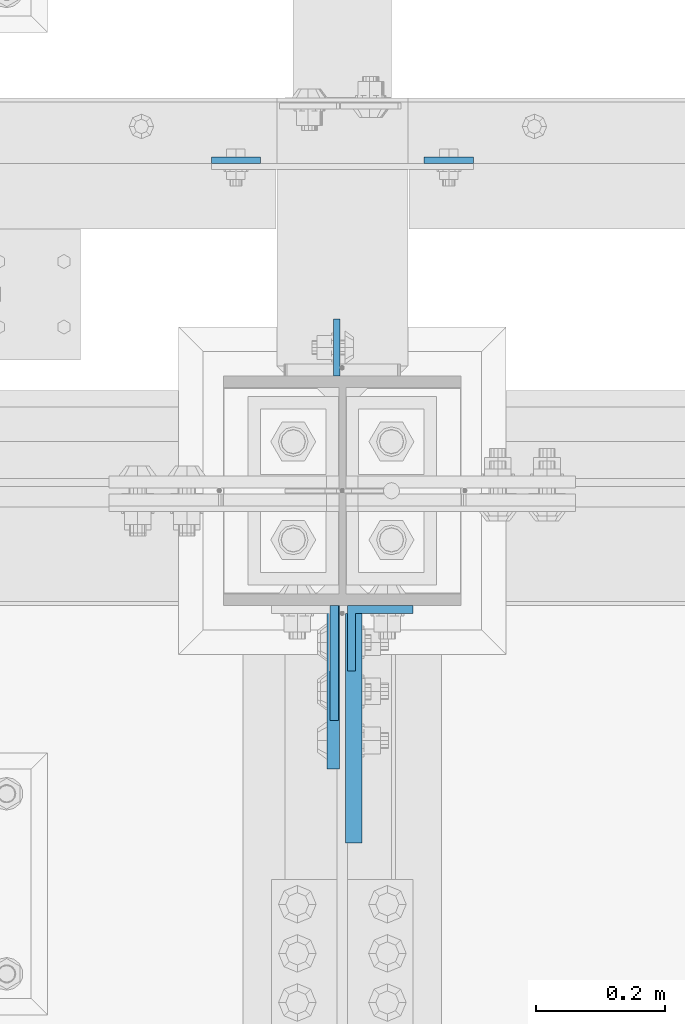
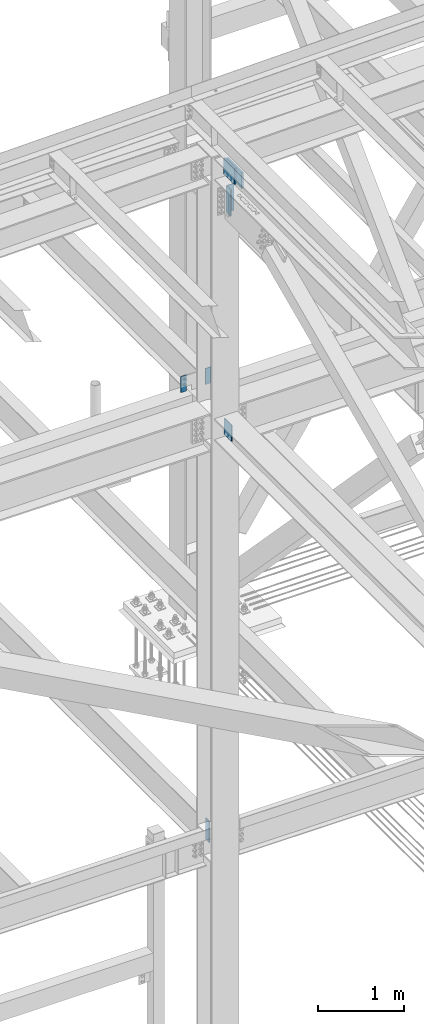
# One storey, part 1595 of 3843: 7 columns, 5 elements without a shape of their own.
"""IFC2X3 building model written with IfcOpenShell, lengths in millimetres."""

import ifcopenshell
import ifcopenshell.guid

model = None  # the IFC model being written
_history = None  # IfcOwnerHistory: only IFC2X3 demands one
_inside = {}  # id of a spatial element -> (the spatial element, [elements in it])
_under = {}  # id of a project, library or spatial element -> (it, [spatial elements below it])
_declared = {}  # id of a project -> (the project, [libraries it declares])
_typed = {}  # id of a type object -> (the type object, [elements of that type])
_made_of = {}  # id of a material, layer set ... -> (it, [elements and type objects made of it])


def new_model(schema):
    """Start an empty IFC model of exactly this schema.

    Asked for "IFC4X3", IfcOpenShell would pick the latest addendum, in which some entities
    have other attributes; the version numbers below select the first issue.
    IFC2X3 requires an IfcOwnerHistory on every rooted entity: one is made here for all.
    """
    global model, _history
    if schema == "IFC4X3":
        model = ifcopenshell.file(schema_version=(4, 3, 0, 0))
    else:
        model = ifcopenshell.file(schema=schema)
    _inside.clear()
    _under.clear()
    _declared.clear()
    _typed.clear()
    _made_of.clear()
    _history = None
    if model.schema == "IFC2X3":
        org = make("IfcOrganization", Name="unknown")
        user = make(
            "IfcPersonAndOrganization",
            ThePerson=make("IfcPerson", FamilyName="unknown"),
            TheOrganization=org,
        )
        app = make(
            "IfcApplication",
            ApplicationDeveloper=org,
            Version="unknown",
            ApplicationFullName="unknown",
            ApplicationIdentifier="unknown",
        )
        _history = make(
            "IfcOwnerHistory",
            OwningUser=user,
            OwningApplication=app,
            ChangeAction="ADDED",
            CreationDate=0,
        )
    return model


def make(cls, **values):
    """One entity of the class cls with the attributes given. An attribute that is None is left unset."""
    return model.create_entity(
        cls, **{name: value for name, value in values.items() if value is not None}
    )


def rooted(cls, **values):
    """An entity with a GlobalId (a new one), such as an element, a storey or a relation."""
    return make(cls, GlobalId=ifcopenshell.guid.new(), OwnerHistory=_history, **values)


def si_unit(unit_type, name, prefix=None):
    """IfcSIUnit, for example si_unit("LENGTHUNIT", "METRE", prefix="MILLI")."""
    return make("IfcSIUnit", UnitType=unit_type, Prefix=prefix, Name=name)


def assignment(units):
    """IfcUnitAssignment: the units of a project."""
    return None if units is None else make("IfcUnitAssignment", Units=units)


def point(xyz):
    """IfcCartesianPoint."""
    return None if xyz is None else make("IfcCartesianPoint", Coordinates=xyz)


def direction(xyz):
    """IfcDirection."""
    return None if xyz is None else make("IfcDirection", DirectionRatios=xyz)


def frame(location, z_axis=None, x_axis=None):
    """IfcAxis2Placement3D, a coordinate frame: its origin and axes. An axis left out is left unset."""
    return make(
        "IfcAxis2Placement3D",
        Location=point(location),
        Axis=direction(z_axis),
        RefDirection=direction(x_axis),
    )


def origin_with_axes():
    """The frame at (0, 0, 0) with the z axis (0, 0, 1) and the x axis (1, 0, 0) written out."""
    return frame((0.0, 0.0, 0.0), z_axis=(0.0, 0.0, 1.0), x_axis=(1.0, 0.0, 0.0))


def place(relative_to, where):
    """IfcLocalPlacement: puts the frame where relative to a parent placement (None: the world)."""
    return make(
        "IfcLocalPlacement", PlacementRelTo=relative_to, RelativePlacement=where
    )


def context(
    kind, dimensions, precision=None, world=None, true_north=None, identifier=None
):
    """IfcGeometricRepresentationContext, for example the 3D "Model" context."""
    return make(
        "IfcGeometricRepresentationContext",
        ContextIdentifier=identifier,
        ContextType=kind,
        CoordinateSpaceDimension=dimensions,
        Precision=precision,
        WorldCoordinateSystem=world,
        TrueNorth=true_north,
    )


def subcontext(parent, identifier, kind, view, scale=None):
    """IfcGeometricRepresentationSubContext, for example "Body" below "Model"."""
    return make(
        "IfcGeometricRepresentationSubContext",
        ContextIdentifier=identifier,
        ContextType=kind,
        ParentContext=parent,
        TargetScale=scale,
        TargetView=view,
    )


def project(units=None, contexts=None):
    """IfcProject with its units and contexts."""
    return rooted(
        "IfcProject",
        Name="project",
        RepresentationContexts=contexts,
        UnitsInContext=assignment(units),
    )


def spatial(cls, under=None, at=None, **own):
    """A site, building, storey or space (cls), placed at a placement, below another one or the project."""
    s = rooted(cls, ObjectPlacement=at, **own)
    if under is not None:
        _under.setdefault(under.id(), (under, []))[1].append(s)
    return s


def faces_of(points, faces, orient=None, outer=None):
    """IfcFace entities. A face is a list of loops; a loop is a list of indices into points, from 0.

    orient and outer hold one flag for each loop. By default every Orientation is true, the
    first loop of a face is its IfcFaceOuterBound and the others are IfcFaceBound.
    """
    made = []
    for i, loops in enumerate(faces):
        bounds = []
        for j, loop in enumerate(loops):
            is_outer = j == 0 if outer is None else outer[i][j]
            bounds.append(
                make(
                    "IfcFaceOuterBound" if is_outer else "IfcFaceBound",
                    Bound=make("IfcPolyLoop", Polygon=[points[k] for k in loop]),
                    Orientation=True if orient is None else orient[i][j],
                )
            )
        made.append(make("IfcFace", Bounds=bounds))
    return made


def faceted_brep(points, faces, orient=None, outer=None, voids=None):
    """IfcFacetedBrep: a solid bounded by flat faces; with voids (closed shells), ...WithVoids."""
    shared = [point(p) for p in points]
    hull = make("IfcClosedShell", CfsFaces=faces_of(shared, faces, orient, outer))
    if voids is None:
        return make("IfcFacetedBrep", Outer=hull)
    return make(
        "IfcFacetedBrepWithVoids",
        Outer=hull,
        Voids=[
            make(cls, CfsFaces=faces_of(shared, fs, o, b)) for cls, fs, o, b in voids
        ],
    )


def shape(context_of_items, identifier, shape_type, items):
    """IfcShapeRepresentation: the items that make up one representation, for example the "Body"."""
    return make(
        "IfcShapeRepresentation",
        ContextOfItems=context_of_items,
        RepresentationIdentifier=identifier,
        RepresentationType=shape_type,
        Items=items,
    )


def material(Name=None, Category=None):
    """IfcMaterial."""
    return make("IfcMaterial", Name=Name, Category=Category)


def made_of(thing, what):
    """Note that an element or type object is made of a material, layer set ...; save() writes the relation."""
    if what is not None:
        _made_of.setdefault(what.id(), (what, []))[1].append(thing)
    return thing


def type_object(cls, material=None, **own):
    """A type object (cls), such as IfcWallType, which elements share."""
    return made_of(rooted(cls, **own), material)


def element(
    cls,
    number,
    at=None,
    inside=None,
    cuts=None,
    type_object=None,
    material=None,
    context=None,
    identifier="Body",
    shape_type=None,
    held_by="IfcProductDefinitionShape",
    body=None,
    shapes=None,
    **own,
):
    """One element of the class cls, such as IfcWall. Its Tag is "e" and its number.

    at: its placement. inside: the storey or other place that contains it. cuts: it is an
    opening in that element (IfcRelVoidsElement). A single representation is given by context,
    identifier, shape_type and body (its items); several are given by shapes. held_by: the class
    of the entity that holds the representations. save() writes the other relations.
    """
    e = rooted(cls, Tag="e%d" % number, ObjectPlacement=at, **own)
    if body is not None:
        shapes = [shape(context, identifier, shape_type, body)]
    if shapes is not None:
        e.Representation = make(held_by, Representations=shapes)
    if inside is not None:
        _inside.setdefault(inside.id(), (inside, []))[1].append(e)
    if cuts is not None:
        rooted(
            "IfcRelVoidsElement", RelatingBuildingElement=cuts, RelatedOpeningElement=e
        )
    if type_object is not None:
        _typed.setdefault(type_object.id(), (type_object, []))[1].append(e)
    return made_of(e, material)


def aggregate(whole, parts):
    """IfcRelAggregates: a whole, such as a stair, and the parts it consists of."""
    return rooted("IfcRelAggregates", RelatingObject=whole, RelatedObjects=parts)


def save(model, path):
    """Write the relations noted so far, then the file.

    IfcRelAggregates (storeys below a building ...), IfcRelContainedInSpatialStructure (elements
    in a storey), IfcRelDefinesByType, IfcRelAssociatesMaterial and IfcRelDeclares: one each for
    every whole, place, type object, material and project.
    """
    for whole, parts in _under.values():
        aggregate(whole, parts)
    for where, things in _inside.values():
        rooted(
            "IfcRelContainedInSpatialStructure",
            RelatedElements=things,
            RelatingStructure=where,
        )
    for kind, things in _typed.values():
        rooted("IfcRelDefinesByType", RelatedObjects=things, RelatingType=kind)
    for what, things in _made_of.values():
        rooted("IfcRelAssociatesMaterial", RelatedObjects=things, RelatingMaterial=what)
    for by, libraries in _declared.values():
        rooted("IfcRelDeclares", RelatingContext=by, RelatedDefinitions=libraries)
    model.write(path)


model = new_model("IFC2X3")

# Units and contexts
model_context = context("Model", 3, precision=1e-05, world=origin_with_axes())
body_context = subcontext(model_context, "Body", "Model", "MODEL_VIEW")
ifc_project = project(units=[si_unit("LENGTHUNIT", "METRE", prefix="MILLI"), si_unit("AREAUNIT", "SQUARE_METRE"), si_unit("VOLUMEUNIT", "CUBIC_METRE"), si_unit("MASSUNIT", "GRAM", prefix="KILO"), si_unit("TIMEUNIT", "SECOND"), si_unit("PLANEANGLEUNIT", "RADIAN"), si_unit("SOLIDANGLEUNIT", "STERADIAN"), si_unit("THERMODYNAMICTEMPERATUREUNIT", "DEGREE_CELSIUS"), si_unit("LUMINOUSINTENSITYUNIT", "LUMEN")], contexts=[model_context])

# Site, building, storey
site_placement = place(None, origin_with_axes())
site = spatial("IfcSite", under=ifc_project, at=site_placement, CompositionType="ELEMENT")
building_placement = place(site_placement, origin_with_axes())
building = spatial("IfcBuilding", under=site, at=building_placement, Name="Undefined", CompositionType="ELEMENT")
storey_placement = place(building_placement, origin_with_axes())
storey = spatial("IfcBuildingStorey", under=building, at=storey_placement, Name="Undefined", CompositionType="ELEMENT", Elevation=0.0)

# Assembly, column
assembly_1_placement = place(storey_placement, origin_with_axes())
assembly_1 = element("IfcElementAssembly", 1, at=assembly_1_placement, inside=storey, Name="GIRT", AssemblyPlace="NOTDEFINED", PredefinedType="RIGID_FRAME")
ifc_material = material(Name="STEEL/A572-50")
column_type_1 = type_object("IfcColumnType", PredefinedType="NOTDEFINED")
column_1_placement = place(assembly_1_placement, frame((70091.3, 92727.4625, 42367.2), z_axis=(-1.0, 0.0, 0.0), x_axis=(0.0, 0.0, 1.0)))
column_1 = element("IfcColumn", 2, at=column_1_placement, type_object=column_type_1, material=ifc_material, Name="PLATE", context=body_context, shape_type="Brep", body=[
    faceted_brep([(0.0, 4.76250000000073, -38.0999999999985), (0.0, 4.76250000000073, 38.0999999999985), (228.599999999999, 4.76249999999709, 38.1000000000058), (228.599999999999, 4.76249999999709, -38.1000000000058), (0.0, -4.76250000000073, 38.0999999999985), (228.599999999999, -4.76249999999709, 38.1000000000058), (0.0, -4.76250000000073, -38.0999999999985), (228.599999999999, -4.76249999999709, -38.1000000000058)], [[[0, 1, 2, 3]], [[1, 4, 5, 2]], [[4, 6, 7, 5]], [[6, 0, 3, 7]], [[5, 7, 3, 2]], [[6, 4, 1, 0]]]),
])
aggregate(assembly_1, [column_1])

assembly_2_placement = place(storey_placement, origin_with_axes())
assembly_2 = element("IfcElementAssembly", 3, at=assembly_2_placement, inside=storey, Name="GIRT", AssemblyPlace="NOTDEFINED", PredefinedType="RIGID_FRAME")
column_2_placement = place(assembly_2_placement, frame((70421.5, 92727.4625, 42367.2), z_axis=(-1.0, 0.0, 0.0), x_axis=(0.0, 0.0, 1.0)))
column_2 = element("IfcColumn", 4, at=column_2_placement, type_object=column_type_1, material=ifc_material, Name="PLATE", context=body_context, shape_type="Brep", body=[
    faceted_brep([(0.0, 4.76250000000073, -38.0999999999985), (0.0, 4.76250000000073, 38.0999999999985), (228.599999999999, 4.76249999999709, 38.1000000000058), (228.599999999999, 4.76249999999709, -38.1000000000058), (0.0, -4.76250000000073, 38.0999999999985), (228.599999999999, -4.76249999999709, 38.1000000000058), (0.0, -4.76250000000073, -38.0999999999985), (228.599999999999, -4.76249999999709, -38.1000000000058)], [[[0, 1, 2, 3]], [[1, 4, 5, 2]], [[4, 6, 7, 5]], [[6, 0, 3, 7]], [[5, 7, 3, 2]], [[6, 4, 1, 0]]]),
])
aggregate(assembly_2, [column_2])

assembly_3_placement = place(storey_placement, origin_with_axes())
assembly_3 = element("IfcElementAssembly", 5, at=assembly_3_placement, inside=storey, Name="COLUMN", AssemblyPlace="NOTDEFINED", PredefinedType="RIGID_FRAME")
column_type_2 = type_object("IfcColumnType", PredefinedType="NOTDEFINED")
column_3_placement = place(assembly_3_placement, frame((70243.699998908, 91947.7679999991, 42131.1279759627), z_axis=(0.0, 1.0, 0.0), x_axis=(0.0, 0.0, 1.0)))
column_3 = element("IfcColumn", 6, at=column_3_placement, type_object=column_type_2, material=ifc_material, Name="PLATE", context=body_context, shape_type="Brep", body=[
    faceted_brep([(0.0, 6.35000000000582, -89.1319999999978), (0.0, 6.35000000000582, 89.1319999999978), (228.599999999999, 6.35000000000582, 89.1319999999978), (228.599999999999, 6.35000000000582, -89.1319999999978), (0.0, -6.35000000000582, 89.1319999999978), (228.599999999999, -6.35000000000582, 89.1319999999978), (0.0, -6.35000000000582, -89.1319999999978), (228.599999999999, -6.35000000000582, -89.1319999999978)], [[[0, 1, 2, 3]], [[1, 4, 5, 2]], [[4, 6, 7, 5]], [[6, 0, 3, 7]], [[5, 7, 3, 2]], [[6, 4, 1, 0]]]),
])

assembly_4_placement = place(storey_placement, origin_with_axes())
assembly_4 = element("IfcElementAssembly", 7, at=assembly_4_placement, inside=storey, Name="PLATE", AssemblyPlace="NOTDEFINED", PredefinedType="RIGID_FRAME")
column_type_3 = type_object("IfcColumnType", Name="L4X4X1/2", PredefinedType="NOTDEFINED")
column_4_placement = place(assembly_4_placement, frame((70315.1375, 91986.0999999455, 45281.9621203218), z_axis=(0.0, -1.0, 0.0), x_axis=(0.0, 0.0, 1.0)))
column_4 = element("IfcColumn", 8, at=column_4_placement, type_object=column_type_3, material=ifc_material, Name="ANGLE", ObjectType="L4X4X1/2", context=body_context, shape_type="Brep", body=[
    faceted_brep([(0.0, 50.8000000000029, -50.8000000000029), (0.0, 50.8000000000029, 50.8000000000029), (381.0, 50.8000000000029, 50.8000000000029), (381.0, 50.8000000000029, -50.8000000000029), (0.0, 38.0999999999985, 50.8000000000029), (381.0, 38.0999999999985, 50.8000000000029), (0.0, 38.0999999999985, -38.0999999999985), (381.0, 38.0999999999985, -38.1000000000058), (0.0, -50.8000000000029, -38.1000000000058), (381.0, -50.8000000000029, -38.1000000000058), (0.0, -50.8000000000029, -50.8000000000029), (381.0, -50.8000000000029, -50.8000000000029)], [[[0, 1, 2, 3]], [[1, 4, 5, 2]], [[4, 6, 7, 5]], [[6, 8, 9, 7]], [[8, 10, 11, 9]], [[10, 0, 3, 11]], [[5, 7, 9, 11, 3, 2]], [[10, 8, 6, 4, 1, 0]]]),
])
aggregate(assembly_4, [column_4])

# Column
column_type_4 = type_object("IfcColumnType", PredefinedType="NOTDEFINED")
column_5_placement = place(assembly_3_placement, frame((70247.66875, 92436.95, 36093.4), z_axis=(0.0, -1.0, 0.0), x_axis=(0.0, 0.0, 1.0)))
column_5 = element("IfcColumn", 9, at=column_5_placement, type_object=column_type_4, material=ifc_material, Name="PLATE", context=body_context, shape_type="Brep", body=[
    faceted_brep([(0.0, 4.76249999999709, -44.4500000000007), (0.0, 4.76249999999709, 44.4500000000007), (304.799999999996, 4.76249999999709, 44.4500000000007), (304.799999999996, 4.76249999999709, -44.4500000000007), (0.0, -4.76249999999709, 44.4500000000007), (304.799999999996, -4.76249999999709, 44.4500000000007), (0.0, -4.76249999999709, -44.4500000000007), (304.799999999996, -4.76249999999709, -44.4500000000007)], [[[0, 1, 2, 3]], [[1, 4, 5, 2]], [[4, 6, 7, 5]], [[6, 0, 3, 7]], [[5, 7, 3, 2]], [[6, 4, 1, 0]]]),
])

column_type_5 = type_object("IfcColumnType", PredefinedType="NOTDEFINED")
column_6_placement = place(assembly_3_placement, frame((70242.1125, 91909.9, 45835.9996203218), z_axis=(0.0, 1.0, 0.0), x_axis=(0.0, 0.0, 1.0)))
column_6 = element("IfcColumn", 10, at=column_6_placement, type_object=column_type_5, material=ifc_material, Name="PLATE", context=body_context, shape_type="Brep", body=[
    faceted_brep([(0.0, 9.52499999999418, -127.0), (0.0, 9.52499999999418, 127.0), (228.599999999999, 9.52499999999418, 127.0), (228.599999999999, 9.52499999999418, -127.0), (0.0, -9.52499999999418, 127.0), (228.599999999999, -9.52499999999418, 127.0), (0.0, -9.52499999999418, -127.0), (228.599999999999, -9.52499999999418, -127.0)], [[[0, 1, 2, 3]], [[1, 4, 5, 2]], [[4, 6, 7, 5]], [[6, 0, 3, 7]], [[5, 7, 3, 2]], [[6, 4, 1, 0]]]),
])

aggregate(assembly_3, [column_3, column_6, column_5])

# Assembly, column
assembly_5_placement = place(storey_placement, origin_with_axes())
assembly_5 = element("IfcElementAssembly", 11, at=assembly_5_placement, inside=storey, Name="BEAM", AssemblyPlace="NOTDEFINED", PredefinedType="RIGID_FRAME")
column_type_6 = type_object("IfcColumnType", PredefinedType="NOTDEFINED")
column_7_placement = place(assembly_5_placement, frame((70273.8625000005, 91846.4, 45835.9996203218), z_axis=(0.0, 1.0, 0.0), x_axis=(0.0, 0.0, 1.0)))
column_7 = element("IfcColumn", 12, at=column_7_placement, type_object=column_type_6, material=ifc_material, Name="PLATE", context=body_context, shape_type="Brep", body=[
    faceted_brep([(-1.45519152283669e-11, 12.7000000000025, -177.800000000003), (-1.45519152283669e-11, 12.7000000000025, 177.800000000003), (228.600000000013, 12.6999999999971, 177.799999999999), (228.600000000013, 12.6999999999971, -177.799999999999), (4.36557456851006e-11, -12.7000000000171, 177.800000000003), (228.600000000013, -12.6999999999971, 177.799999999999), (4.36557456851006e-11, -12.7000000000171, -177.800000000003), (228.600000000013, -12.6999999999971, -177.799999999999)], [[[0, 1, 2, 3]], [[1, 4, 5, 2]], [[4, 6, 7, 5]], [[6, 0, 3, 7]], [[5, 7, 3, 2]], [[6, 4, 1, 0]]]),
])
aggregate(assembly_5, [column_7])

save(model, "model.ifc")
